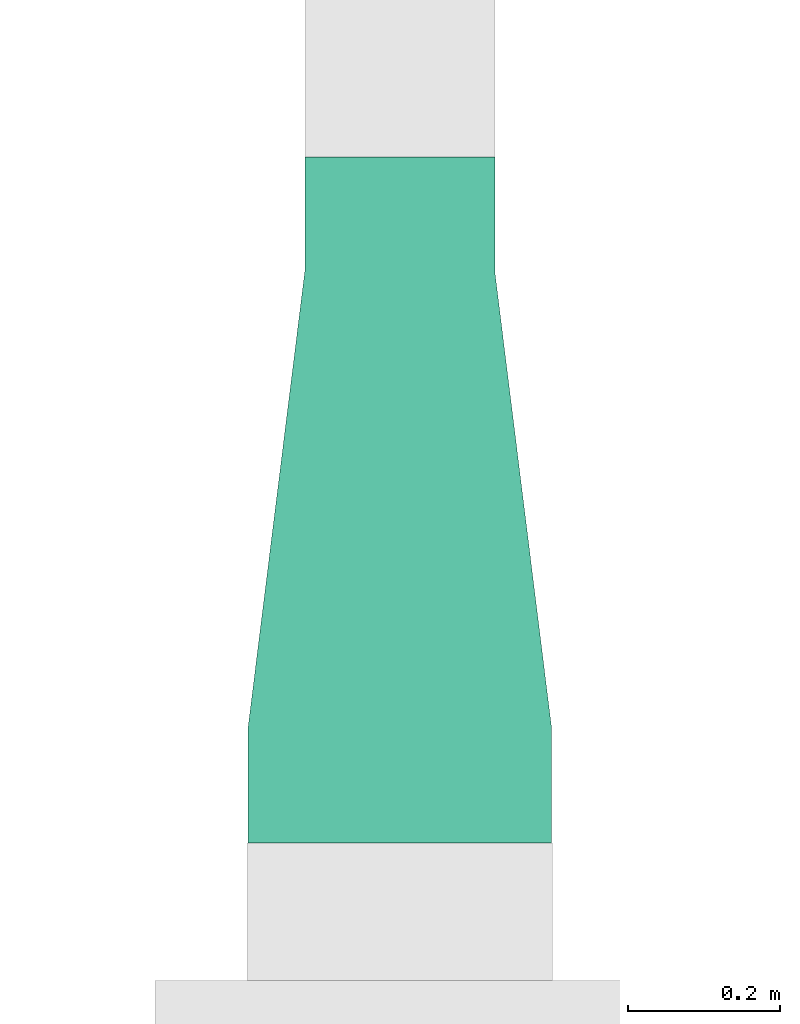
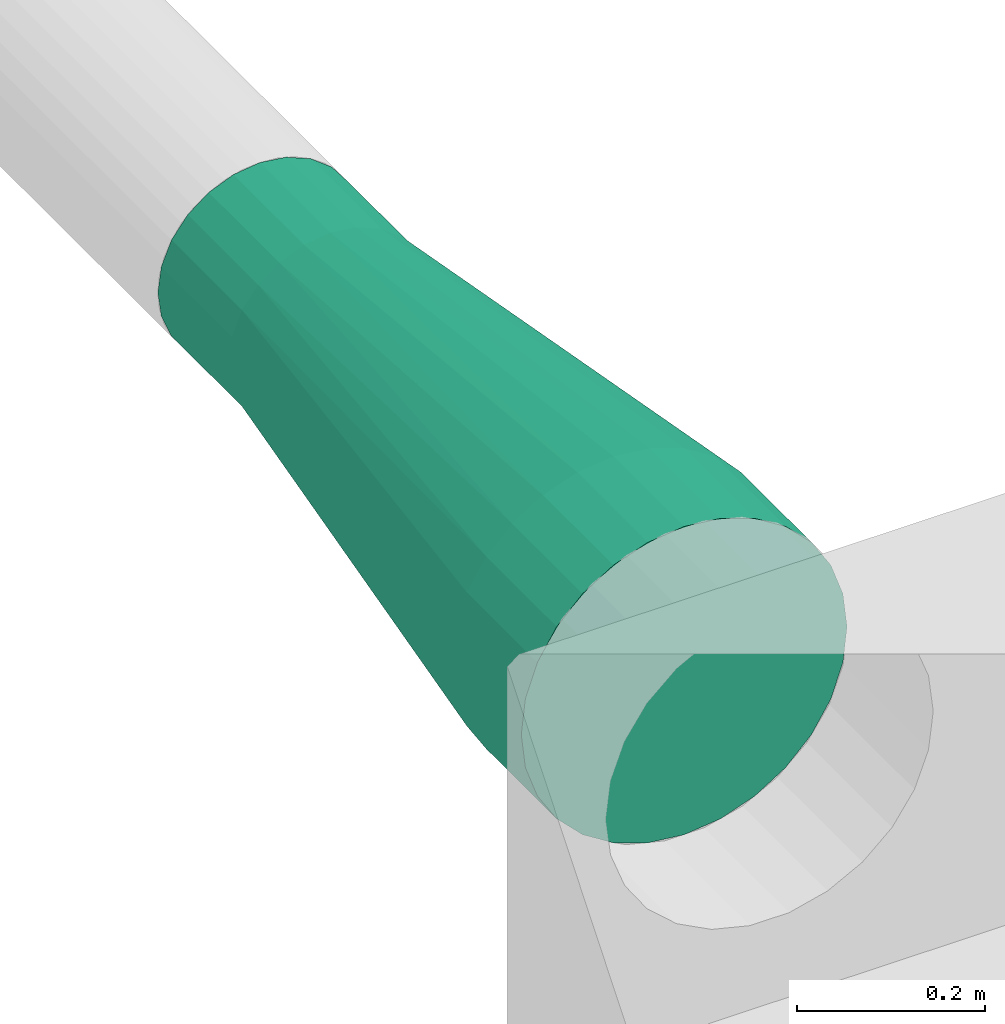
# One storey, part 5 of 6: 1 flow fitting.
"""IFC2X3 building model written with IfcOpenShell, lengths in metres."""

from ifc_helpers import new_model, entity, si_unit, converted_unit, derived_unit, direction, frame, origin, place, context, subcontext, project, spatial, faceted_brep, source, transform, mapped, type_object, type_shapes, element, save


model = new_model("IFC2X3")

# Units and contexts
model_context = context("Model", 3, precision=1e-05, world=origin(), true_north=direction((6.12303176911189e-17, 1.0)))
body_context = subcontext(model_context, "Body", "Model", "MODEL_VIEW")
ifc_project = project(units=[si_unit("LENGTHUNIT", "METRE"), si_unit("AREAUNIT", "SQUARE_METRE"), si_unit("VOLUMEUNIT", "CUBIC_METRE"), converted_unit("PLANEANGLEUNIT", "DEGREE", entity("IfcRatioMeasure", 0.0174532925199433), si_unit("PLANEANGLEUNIT", "RADIAN"), dimensions=[0, 0, 0, 0, 0, 0, 0]), si_unit("MASSUNIT", "GRAM", prefix="KILO"), derived_unit("MASSDENSITYUNIT", [(si_unit("MASSUNIT", "GRAM", prefix="KILO"), 1), (si_unit("LENGTHUNIT", "METRE"), -3)]), si_unit("TIMEUNIT", "SECOND"), si_unit("FREQUENCYUNIT", "HERTZ"), si_unit("THERMODYNAMICTEMPERATUREUNIT", "DEGREE_CELSIUS"), derived_unit("THERMALTRANSMITTANCEUNIT", [(si_unit("MASSUNIT", "GRAM", prefix="KILO"), 1), (si_unit("THERMODYNAMICTEMPERATUREUNIT", "KELVIN"), -1), (si_unit("TIMEUNIT", "SECOND"), -3)]), derived_unit("VOLUMETRICFLOWRATEUNIT", [(si_unit("LENGTHUNIT", "METRE"), 3), (si_unit("TIMEUNIT", "SECOND"), -1)]), si_unit("ELECTRICCURRENTUNIT", "AMPERE"), si_unit("ELECTRICVOLTAGEUNIT", "VOLT"), si_unit("POWERUNIT", "WATT"), si_unit("FORCEUNIT", "NEWTON", prefix="KILO"), si_unit("ILLUMINANCEUNIT", "LUX"), si_unit("LUMINOUSFLUXUNIT", "LUMEN"), si_unit("LUMINOUSINTENSITYUNIT", "CANDELA"), derived_unit("USERDEFINED", [(si_unit("MASSUNIT", "GRAM", prefix="KILO"), -1), (si_unit("LENGTHUNIT", "METRE"), -2), (si_unit("TIMEUNIT", "SECOND"), 3), (si_unit("LUMINOUSFLUXUNIT", "LUMEN"), 1)]), derived_unit("LINEARVELOCITYUNIT", [(si_unit("LENGTHUNIT", "METRE"), 1), (si_unit("TIMEUNIT", "SECOND"), -1)]), si_unit("PRESSUREUNIT", "PASCAL"), derived_unit("USERDEFINED", [(si_unit("LENGTHUNIT", "METRE"), -2), (si_unit("MASSUNIT", "GRAM", prefix="KILO"), 1), (si_unit("TIMEUNIT", "SECOND"), -2)])], contexts=[model_context])

# Site, building, storey
site_placement = place(None, origin())
site = spatial("IfcSite", under=ifc_project, at=site_placement, CompositionType="ELEMENT")
building_placement = place(site_placement, origin())
building = spatial("IfcBuilding", under=site, at=building_placement, CompositionType="ELEMENT")
storey_placement = place(building_placement, origin())
storey = spatial("IfcBuildingStorey", under=building, at=storey_placement, Name="1 - RDC", CompositionType="ELEMENT", Elevation=1.94210219716249e-13)

# Flow fitting
duct_fitting_type = type_object("IfcDuctFittingType", Name="Standard", PredefinedType="NOTDEFINED")
shared_shape = source(origin(), body_context, "Body", "Brep", [
    faceted_brep([(0.752699999999996, 0.0, -0.199999999999998), (0.752699999999996, -0.0445041867912522, -0.194985582436364), (0.752699999999996, -0.0867767478235019, -0.180193773580484), (0.752699999999996, -0.124697960371738, -0.156366296493606), (0.752699999999996, -0.156366296493598, -0.124697960371747), (0.752699999999996, -0.180193773580477, -0.0867767478235117), (0.752699999999997, -0.194985582436358, -0.0445041867912625), (0.752699999999997, -0.199999999999992, 0.0), (0.752699999999997, -0.194985582436357, 0.0445041867912633), (0.752699999999997, -0.180193773580477, 0.0867767478235121), (0.752699999999997, -0.156366296493599, 0.124697960371747), (0.752699999999997, -0.12469796037174, 0.156366296493607), (0.752699999999997, -0.0867767478235052, 0.180193773580485), (0.752699999999997, -0.0445041867912565, 0.194985582436366), (0.752699999999997, 0.0, 0.200000000000001), (0.752699999999997, 0.0445041867912693, 0.194985582436366), (0.752699999999997, 0.086776747823518, 0.180193773580486), (0.752699999999997, 0.124697960371753, 0.156366296493608), (0.752699999999997, 0.156366296493612, 0.124697960371749), (0.752699999999997, 0.18019377358049, 0.0867767478235143), (0.752699999999997, 0.194985582436371, 0.0445041867912659), (0.752699999999997, 0.200000000000007, 0.0), (0.752699999999997, 0.194985582436372, -0.0445041867912591), (0.752699999999996, 0.180193773580492, -0.0867767478235076), (0.752699999999996, 0.156366296493614, -0.124697960371743), (0.752699999999996, 0.124697960371756, -0.156366296493602), (0.752699999999996, 0.0867767478235207, -0.18019377358048), (0.752699999999996, 0.0445041867912724, -0.194985582436361), (0.9027, 0.124697960371753, 0.156366296493608), (0.9027, 0.086776747823518, 0.180193773580485), (0.9027, 0.0445041867912693, 0.194985582436366), (0.9027, 0.0, 0.200000000000001), (0.9027, -0.0445041867912565, 0.194985582436366), (0.9027, -0.0867767478235052, 0.180193773580485), (0.9027, -0.12469796037174, 0.156366296493606), (0.902699999999999, -0.156366296493599, 0.124697960371747), (0.902699999999999, -0.180193773580477, 0.0867767478235117), (0.902699999999999, -0.194985582436357, 0.0445041867912628), (0.902699999999999, -0.199999999999994, 0.0), (0.902699999999999, -0.194985582436358, -0.0445041867912629), (0.902699999999999, -0.180193773580477, -0.0867767478235122), (0.902699999999999, -0.156366296493598, -0.124697960371748), (0.902699999999998, -0.124697960371738, -0.156366296493607), (0.902699999999998, -0.0867767478235019, -0.180193773580484), (0.902699999999998, -0.0445041867912522, -0.194985582436365), (0.902699999999998, 0.0, -0.199999999999997), (0.902699999999998, 0.0445041867912724, -0.194985582436362), (0.902699999999998, 0.0867767478235207, -0.180193773580481), (0.902699999999998, 0.124697960371756, -0.156366296493603), (0.902699999999999, 0.156366296493614, -0.124697960371743), (0.902699999999999, 0.180193773580492, -0.0867767478235081), (0.902699999999999, 0.194985582436372, -0.0445041867912596), (0.902699999999999, 0.200000000000007, 0.0), (0.902699999999999, 0.194985582436371, 0.0445041867912654), (0.902699999999999, 0.18019377358049, 0.0867767478235138), (0.902699999999999, 0.156366296493612, 0.124697960371749)], [[[0, 1, 2, 3, 4, 5, 6, 7, 8, 9, 10, 11, 12, 13, 14, 15, 16, 17, 18, 19, 20, 21, 22, 23, 24, 25, 26, 27]], [[28, 29, 30, 31, 32, 33, 34, 35, 36, 37, 38, 39, 40, 41, 42, 43, 44, 45, 46, 47, 48, 49, 50, 51, 52, 53, 54, 55]], [[1, 0, 45, 44]], [[2, 1, 44, 43]], [[3, 2, 43, 42]], [[42, 41, 4, 3]], [[5, 4, 41, 40]], [[6, 5, 40, 39]], [[7, 6, 39, 38]], [[22, 21, 52, 51]], [[23, 22, 51, 50]], [[24, 23, 50, 49]], [[49, 48, 25, 24]], [[26, 25, 48, 47]], [[27, 26, 47, 46]], [[0, 27, 46, 45]], [[15, 14, 31, 30]], [[16, 15, 30, 29]], [[17, 16, 29, 28]], [[28, 55, 18, 17]], [[19, 18, 55, 54]], [[20, 19, 54, 53]], [[21, 20, 53, 52]], [[8, 7, 38, 37]], [[9, 8, 37, 36]], [[10, 9, 36, 35]], [[35, 34, 11, 10]], [[12, 11, 34, 33]], [[13, 12, 33, 32]], [[14, 13, 32, 31]]]),
    faceted_brep([(0.752700000000004, 0.194985582436363, 0.0445041867912615), (0.752700000000004, 0.180193773580482, 0.08677674782351), (0.752700000000003, 0.156366296493605, 0.124697960371745), (0.752700000000003, 0.124697960371745, 0.156366296493604), (0.752700000000003, 0.0867767478235107, 0.180193773580482), (0.752700000000003, 0.0445041867912623, 0.194985582436363), (0.752700000000003, 0.0, 0.2), (0.752700000000003, -0.044504186791264, 0.194985582436365), (0.752700000000003, -0.0867767478235125, 0.180193773580484), (0.752700000000003, -0.124697960371748, 0.156366296493607), (0.752700000000002, -0.156366296493607, 0.124697960371748), (0.752700000000002, -0.180193773580485, 0.0867767478235127), (0.752700000000002, -0.194985582436366, 0.044504186791264), (0.752700000000002, -0.200000000000003, 0.0), (0.752700000000002, -0.194985582436368, -0.0445041867912631), (0.752700000000002, -0.180193773580487, -0.0867767478235125), (0.752700000000002, -0.156366296493608, -0.124697960371748), (0.752700000000003, -0.124697960371748, -0.156366296493608), (0.752700000000003, -0.0867767478235123, -0.180193773580485), (0.752700000000003, -0.0445041867912629, -0.194985582436366), (0.752700000000003, 0.0, -0.199999999999999), (0.752700000000003, 0.0445041867912601, -0.194985582436364), (0.752700000000003, 0.0867767478235086, -0.180193773580483), (0.752700000000003, 0.124697960371744, -0.156366296493606), (0.752700000000003, 0.156366296493603, -0.124697960371747), (0.752700000000004, 0.180193773580481, -0.0867767478235118), (0.752700000000004, 0.194985582436362, -0.0445041867912633), (0.752700000000004, 0.199999999999998, 0.0), (0.150000000000002, 0.108253175473054, -0.0625), (0.150000000000002, 0.0883883476483179, -0.088388347648318), (0.150000000000002, 0.0624999999999995, -0.108253175473054), (0.150000000000001, 0.0323523806378147, -0.120740728286133), (0.150000000000001, 0.0, -0.125), (0.150000000000001, -0.0323523806378145, -0.120740728286134), (0.150000000000001, -0.0625000000000001, -0.108253175473056), (0.150000000000001, -0.0883883476483191, -0.0883883476483196), (0.150000000000001, -0.108253175473056, -0.0625000000000008), (0.150000000000001, -0.120740728286135, -0.0323523806378154), (0.150000000000001, -0.125, 0.0), (0.150000000000001, -0.120740728286133, 0.0323523806378156), (0.150000000000001, -0.108253175473054, 0.0625000000000003), (0.150000000000001, -0.0883883476483178, 0.0883883476483186), (0.150000000000001, -0.0624999999999993, 0.108253175473055), (0.150000000000001, -0.0323523806378144, 0.120740728286133), (0.150000000000001, 0.0, 0.124999999999998), (0.150000000000001, 0.0323523806378157, 0.120740728286132), (0.150000000000002, 0.0625000000000003, 0.108253175473053), (0.150000000000002, 0.0883883476483184, 0.0883883476483172), (0.150000000000002, 0.108253175473055, 0.0624999999999989), (0.150000000000002, 0.120740728286133, 0.0323523806378141), (0.150000000000002, 0.125, 0.0), (0.150000000000002, 0.120740728286133, -0.0323523806378152)], [[[0, 1, 2, 3, 4, 5, 6, 7, 8, 9, 10, 11, 12, 13, 14, 15, 16, 17, 18, 19, 20, 21, 22, 23, 24, 25, 26, 27]], [[28, 29, 30, 31, 32, 33, 34, 35, 36, 37, 38, 39, 40, 41, 42, 43, 44, 45, 46, 47, 48, 49, 50, 51]], [[14, 38, 37]], [[15, 37, 36]], [[14, 13, 38]], [[15, 14, 37]], [[36, 16, 15]], [[36, 35, 16]], [[35, 34, 17]], [[33, 32, 19]], [[34, 33, 18]], [[17, 34, 18]], [[18, 33, 19]], [[32, 20, 19]], [[35, 17, 16]], [[7, 44, 43]], [[8, 43, 42]], [[7, 6, 44]], [[8, 7, 43]], [[42, 9, 8]], [[42, 41, 9]], [[41, 40, 10]], [[39, 38, 12]], [[40, 39, 11]], [[10, 40, 11]], [[11, 39, 12]], [[38, 13, 12]], [[41, 10, 9]], [[0, 50, 49]], [[1, 49, 48]], [[0, 27, 50]], [[1, 0, 49]], [[48, 2, 1]], [[48, 47, 2]], [[47, 46, 3]], [[45, 44, 5]], [[46, 45, 4]], [[3, 46, 4]], [[4, 45, 5]], [[44, 6, 5]], [[47, 3, 2]], [[21, 32, 31]], [[22, 31, 30]], [[21, 20, 32]], [[22, 21, 31]], [[30, 23, 22]], [[30, 29, 23]], [[29, 28, 24]], [[51, 50, 26]], [[28, 51, 25]], [[24, 28, 25]], [[25, 51, 26]], [[50, 27, 26]], [[29, 24, 23]]]),
    faceted_brep([(0.0, 0.0, -0.125), (0.0, -0.0323523806378139, -0.120740728286135), (0.0, -0.0624999999999995, -0.108253175473056), (0.0, -0.0883883476483187, -0.08838834764832), (0.0, -0.108253175473056, -0.0625000000000014), (0.0, -0.120740728286135, -0.0323523806378162), (0.0, -0.125, 0.0), (0.0, -0.120740728286134, 0.0323523806378141), (0.0, -0.108253175473055, 0.062499999999999), (0.0, -0.0883883476483191, 0.0883883476483176), (0.0, -0.0625000000000008, 0.108253175473054), (0.0, -0.0323523806378161, 0.120740728286133), (0.0, 0.0, 0.125), (0.0, 0.0323523806378142, 0.120740728286133), (0.0, 0.062499999999999, 0.108253175473055), (0.0, 0.0883883476483175, 0.0883883476483187), (0.0, 0.108253175473054, 0.0625000000000004), (0.0, 0.120740728286133, 0.0323523806378157), (0.0, 0.125, 0.0), (0.0, 0.120740728286134, -0.0323523806378137), (0.0, 0.108253175473055, -0.0624999999999986), (0.0, 0.0883883476483192, -0.088388347648317), (0.0, 0.062500000000001, -0.108253175473054), (0.0, 0.0323523806378163, -0.120740728286132), (0.150000000000001, 0.0323523806378158, -0.120740728286132), (0.150000000000001, 0.0625000000000005, -0.108253175473054), (0.150000000000001, 0.0883883476483187, -0.088388347648317), (0.150000000000001, 0.108253175473055, -0.0624999999999986), (0.150000000000001, 0.120740728286133, -0.0323523806378137), (0.150000000000001, 0.124999999999999, 0.0), (0.150000000000001, 0.120740728286132, 0.0323523806378157), (0.150000000000001, 0.108253175473054, 0.0625000000000004), (0.150000000000001, 0.088388347648317, 0.0883883476483187), (0.150000000000001, 0.0624999999999985, 0.108253175473055), (0.150000000000001, 0.0323523806378137, 0.120740728286133), (0.15, 0.0, 0.125), (0.15, -0.0323523806378166, 0.120740728286133), (0.15, -0.0625000000000013, 0.108253175473054), (0.15, -0.0883883476483196, 0.0883883476483176), (0.15, -0.108253175473056, 0.062499999999999), (0.15, -0.120740728286134, 0.0323523806378141), (0.15, -0.125000000000002, 0.0), (0.15, -0.120740728286135, -0.0323523806378162), (0.15, -0.108253175473056, -0.0625000000000014), (0.15, -0.0883883476483192, -0.08838834764832), (0.15, -0.0625, -0.108253175473056), (0.15, -0.0323523806378144, -0.120740728286135), (0.15, 0.0, -0.124999999999999)], [[[0, 1, 2, 3, 4, 5, 6, 7, 8, 9, 10, 11, 12, 13, 14, 15, 16, 17, 18, 19, 20, 21, 22, 23]], [[24, 25, 26, 27, 28, 29, 30, 31, 32, 33, 34, 35, 36, 37, 38, 39, 40, 41, 42, 43, 44, 45, 46, 47]], [[1, 0, 47, 46]], [[2, 1, 46, 45]], [[45, 44, 3, 2]], [[5, 4, 43, 42]], [[6, 5, 42, 41]], [[44, 43, 4, 3]], [[19, 18, 29, 28]], [[20, 19, 28, 27]], [[27, 26, 21, 20]], [[23, 22, 25, 24]], [[0, 23, 24, 47]], [[26, 25, 22, 21]], [[13, 12, 35, 34]], [[14, 13, 34, 33]], [[33, 32, 15, 14]], [[17, 16, 31, 30]], [[18, 17, 30, 29]], [[32, 31, 16, 15]], [[7, 6, 41, 40]], [[8, 7, 40, 39]], [[39, 38, 9, 8]], [[11, 10, 37, 36]], [[12, 11, 36, 35]], [[38, 37, 10, 9]]]),
])
type_shapes(duct_fitting_type, [shared_shape])
flow_fitting_placement = place(storey_placement, frame((5.79472147345444, -2.66931978878917, 3.959), z_axis=(0.0, 0.0, 1.0), x_axis=(0.0, -1.0, 0.0)))
element("IfcFlowFitting", 1, at=flow_fitting_placement, inside=storey, type_object=duct_fitting_type, Name="Transformation ronde - Joint Standard", ObjectType="Standard", context=body_context, shape_type="MappedRepresentation", body=[
    mapped(shared_shape, transform((0.0, 0.0, 0.0), scale=1.0)),
])

save(model, "model.ifc")
